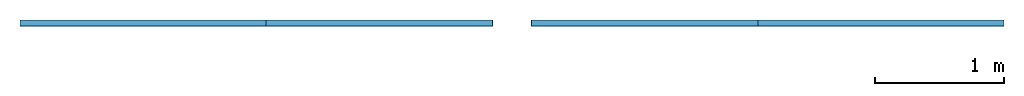
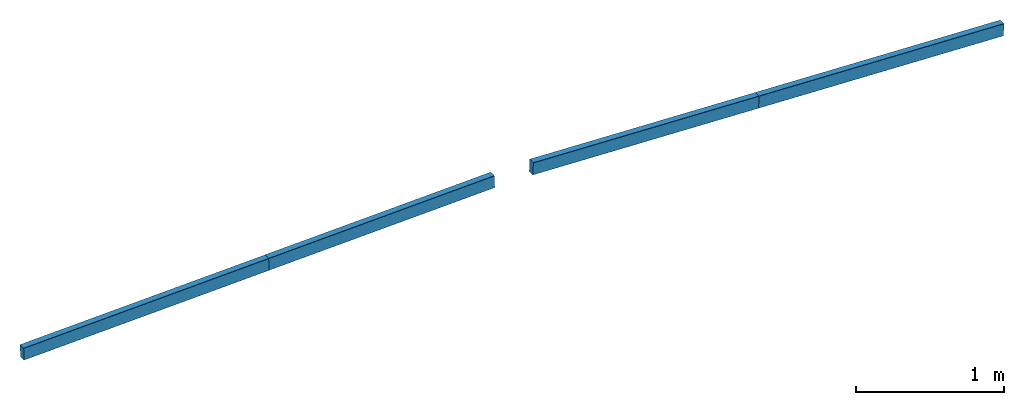
# One storey: 4 members.
"""IFC4 building model written with IfcOpenShell, lengths in metres."""

from ifc_helpers import new_model, entity, si_unit, derived_unit, frame, origin_with_axes, place, context, project, spatial, mirrored_profile, composite_profile, extrude, material, material_profile, profile_set, profile_usage, element, save


model = new_model("IFC4")

# Units and contexts
model_context = context("Model", 3, world=origin_with_axes())
ifc_project = project(units=[si_unit("LENGTHUNIT", "METRE"), si_unit("AREAUNIT", "SQUARE_METRE"), si_unit("VOLUMEUNIT", "CUBIC_METRE"), derived_unit("SECTIONMODULUSUNIT", [(si_unit("LENGTHUNIT", "METRE"), 3)]), derived_unit("MOMENTOFINERTIAUNIT", [(si_unit("LENGTHUNIT", "METRE"), 4)]), si_unit("PLANEANGLEUNIT", "RADIAN"), si_unit("TIMEUNIT", "SECOND"), si_unit("THERMODYNAMICTEMPERATUREUNIT", "DEGREE_CELSIUS"), derived_unit("THERMALEXPANSIONCOEFFICIENTUNIT", [(si_unit("THERMODYNAMICTEMPERATUREUNIT", "DEGREE_CELSIUS"), -1)])], contexts=[model_context])

# Site, building, storey
site = spatial("IfcSite", under=ifc_project, CompositionType="ELEMENT")
building = spatial("IfcBuilding", under=site, Name="Building", CompositionType="ELEMENT")
storey = spatial("IfcBuildingStorey", under=building, Name="LEVEL 7", CompositionType="ELEMENT", Elevation=6.956695)

# Members
ifc_material = material(Name="SAE 1020")
cartesian_point_1 = entity("IfcCartesianPoint", [0.0044999998, 0.050000001])
ifc_direction_1 = entity("IfcDirection", [1.0, 0.0])
cartesian_point_2 = entity("IfcCartesianPoint", [0.0015, 0.046999998])
cartesian_point_3 = entity("IfcCartesianPoint", [0.0015, -0.046999998])
cartesian_point_4 = entity("IfcCartesianPoint", [0.0044999998, -0.050000001])
cartesian_point_5 = entity("IfcCartesianPoint", [0.0044999998, 0.050000001])
ifc_direction_2 = entity("IfcDirection", [1.0, 0.0])
cartesian_point_6 = entity("IfcCartesianPoint", [0.0015, 0.046999998])
cartesian_point_7 = entity("IfcCartesianPoint", [0.0015, -0.046999998])
cartesian_point_8 = entity("IfcCartesianPoint", [0.0044999998, -0.050000001])
ifc_material_profile_1 = material_profile(ifc_material, composite_profile([entity("IfcCenterLineProfileDef", "AREA", None, entity("IfcCompositeCurve", [entity("IfcCompositeCurveSegment", "CONTSAMEGRADIENT", True, entity("IfcPolyline", [entity("IfcCartesianPoint", [0.0515, 0.050000001]), cartesian_point_1])), entity("IfcCompositeCurveSegment", "CONTSAMEGRADIENT", True, entity("IfcTrimmedCurve", entity("IfcCircle", entity("IfcAxis2Placement2D", entity("IfcCartesianPoint", [0.0044999998, 0.047000002]), ifc_direction_1), 0.003), [cartesian_point_1], [cartesian_point_2], True, "CARTESIAN")), entity("IfcCompositeCurveSegment", "CONTSAMEGRADIENT", True, entity("IfcPolyline", [cartesian_point_2, cartesian_point_3])), entity("IfcCompositeCurveSegment", "CONTSAMEGRADIENT", True, entity("IfcTrimmedCurve", entity("IfcCircle", entity("IfcAxis2Placement2D", entity("IfcCartesianPoint", [0.0044999998, -0.047000002]), ifc_direction_1), 0.003), [cartesian_point_3], [cartesian_point_4], True, "CARTESIAN")), entity("IfcCompositeCurveSegment", "CONTSAMEGRADIENT", True, entity("IfcPolyline", [cartesian_point_4, entity("IfcCartesianPoint", [0.0515, -0.050000001])]))], "UNKNOWN"), 0.003), mirrored_profile(entity("IfcCenterLineProfileDef", "AREA", None, entity("IfcCompositeCurve", [entity("IfcCompositeCurveSegment", "CONTSAMEGRADIENT", True, entity("IfcPolyline", [entity("IfcCartesianPoint", [0.0515, 0.050000001]), cartesian_point_5])), entity("IfcCompositeCurveSegment", "CONTSAMEGRADIENT", True, entity("IfcTrimmedCurve", entity("IfcCircle", entity("IfcAxis2Placement2D", entity("IfcCartesianPoint", [0.0044999998, 0.047000002]), ifc_direction_2), 0.003), [cartesian_point_5], [cartesian_point_6], True, "CARTESIAN")), entity("IfcCompositeCurveSegment", "CONTSAMEGRADIENT", True, entity("IfcPolyline", [cartesian_point_6, cartesian_point_7])), entity("IfcCompositeCurveSegment", "CONTSAMEGRADIENT", True, entity("IfcTrimmedCurve", entity("IfcCircle", entity("IfcAxis2Placement2D", entity("IfcCartesianPoint", [0.0044999998, -0.047000002]), ifc_direction_2), 0.003), [cartesian_point_7], [cartesian_point_8], True, "CARTESIAN")), entity("IfcCompositeCurveSegment", "CONTSAMEGRADIENT", True, entity("IfcPolyline", [cartesian_point_8, entity("IfcCartesianPoint", [0.0515, -0.050000001])]))], "UNKNOWN"), 0.003))]))
ifc_profile_set_1 = profile_set([ifc_material_profile_1])
ifc_profile_usage_1 = profile_usage(ifc_profile_set_1, cardinal=10)
member_1_placement = place(None, frame((11.43947, 3.166, 6.956695), z_axis=(0.99930329, 0.0, 0.037321907), x_axis=(0.0, 1.0, 0.0)))
cartesian_point_9 = entity("IfcCartesianPoint", [0.0044999998, 0.050000001])
ifc_direction_3 = entity("IfcDirection", [1.0, 0.0])
cartesian_point_10 = entity("IfcCartesianPoint", [0.0015, 0.046999998])
cartesian_point_11 = entity("IfcCartesianPoint", [0.0015, -0.046999998])
cartesian_point_12 = entity("IfcCartesianPoint", [0.0044999998, -0.050000001])
cartesian_point_13 = entity("IfcCartesianPoint", [0.0044999998, 0.050000001])
ifc_direction_4 = entity("IfcDirection", [1.0, 0.0])
cartesian_point_14 = entity("IfcCartesianPoint", [0.0015, 0.046999998])
cartesian_point_15 = entity("IfcCartesianPoint", [0.0015, -0.046999998])
cartesian_point_16 = entity("IfcCartesianPoint", [0.0044999998, -0.050000001])
element("IfcMember", 1, at=member_1_placement, inside=storey, material=ifc_profile_usage_1, Name="808", context=model_context, shape_type="SweptSolid", body=[
    extrude(composite_profile([entity("IfcCenterLineProfileDef", "AREA", None, entity("IfcCompositeCurve", [entity("IfcCompositeCurveSegment", "CONTSAMEGRADIENT", True, entity("IfcPolyline", [entity("IfcCartesianPoint", [0.0515, 0.050000001]), cartesian_point_9])), entity("IfcCompositeCurveSegment", "CONTSAMEGRADIENT", True, entity("IfcTrimmedCurve", entity("IfcCircle", entity("IfcAxis2Placement2D", entity("IfcCartesianPoint", [0.0044999998, 0.047000002]), ifc_direction_3), 0.003), [cartesian_point_9], [cartesian_point_10], True, "CARTESIAN")), entity("IfcCompositeCurveSegment", "CONTSAMEGRADIENT", True, entity("IfcPolyline", [cartesian_point_10, cartesian_point_11])), entity("IfcCompositeCurveSegment", "CONTSAMEGRADIENT", True, entity("IfcTrimmedCurve", entity("IfcCircle", entity("IfcAxis2Placement2D", entity("IfcCartesianPoint", [0.0044999998, -0.047000002]), ifc_direction_3), 0.003), [cartesian_point_11], [cartesian_point_12], True, "CARTESIAN")), entity("IfcCompositeCurveSegment", "CONTSAMEGRADIENT", True, entity("IfcPolyline", [cartesian_point_12, entity("IfcCartesianPoint", [0.0515, -0.050000001])]))], "UNKNOWN"), 0.003), mirrored_profile(entity("IfcCenterLineProfileDef", "AREA", None, entity("IfcCompositeCurve", [entity("IfcCompositeCurveSegment", "CONTSAMEGRADIENT", True, entity("IfcPolyline", [entity("IfcCartesianPoint", [0.0515, 0.050000001]), cartesian_point_13])), entity("IfcCompositeCurveSegment", "CONTSAMEGRADIENT", True, entity("IfcTrimmedCurve", entity("IfcCircle", entity("IfcAxis2Placement2D", entity("IfcCartesianPoint", [0.0044999998, 0.047000002]), ifc_direction_4), 0.003), [cartesian_point_13], [cartesian_point_14], True, "CARTESIAN")), entity("IfcCompositeCurveSegment", "CONTSAMEGRADIENT", True, entity("IfcPolyline", [cartesian_point_14, cartesian_point_15])), entity("IfcCompositeCurveSegment", "CONTSAMEGRADIENT", True, entity("IfcTrimmedCurve", entity("IfcCircle", entity("IfcAxis2Placement2D", entity("IfcCartesianPoint", [0.0044999998, -0.047000002]), ifc_direction_4), 0.003), [cartesian_point_15], [cartesian_point_16], True, "CARTESIAN")), entity("IfcCompositeCurveSegment", "CONTSAMEGRADIENT", True, entity("IfcPolyline", [cartesian_point_16, entity("IfcCartesianPoint", [0.0515, -0.050000001])]))], "UNKNOWN"), 0.003))]), origin_with_axes(), (0.0, 0.0, 1.0), 1.9065156),
])
cartesian_point_17 = entity("IfcCartesianPoint", [0.0044999998, 0.050000001])
ifc_direction_5 = entity("IfcDirection", [1.0, 0.0])
cartesian_point_18 = entity("IfcCartesianPoint", [0.0015, 0.046999998])
cartesian_point_19 = entity("IfcCartesianPoint", [0.0015, -0.046999998])
cartesian_point_20 = entity("IfcCartesianPoint", [0.0044999998, -0.050000001])
cartesian_point_21 = entity("IfcCartesianPoint", [0.0044999998, 0.050000001])
ifc_direction_6 = entity("IfcDirection", [1.0, 0.0])
cartesian_point_22 = entity("IfcCartesianPoint", [0.0015, 0.046999998])
cartesian_point_23 = entity("IfcCartesianPoint", [0.0015, -0.046999998])
cartesian_point_24 = entity("IfcCartesianPoint", [0.0044999998, -0.050000001])
ifc_material_profile_2 = material_profile(ifc_material, composite_profile([entity("IfcCenterLineProfileDef", "AREA", None, entity("IfcCompositeCurve", [entity("IfcCompositeCurveSegment", "CONTSAMEGRADIENT", True, entity("IfcPolyline", [entity("IfcCartesianPoint", [0.0515, 0.050000001]), cartesian_point_17])), entity("IfcCompositeCurveSegment", "CONTSAMEGRADIENT", True, entity("IfcTrimmedCurve", entity("IfcCircle", entity("IfcAxis2Placement2D", entity("IfcCartesianPoint", [0.0044999998, 0.047000002]), ifc_direction_5), 0.003), [cartesian_point_17], [cartesian_point_18], True, "CARTESIAN")), entity("IfcCompositeCurveSegment", "CONTSAMEGRADIENT", True, entity("IfcPolyline", [cartesian_point_18, cartesian_point_19])), entity("IfcCompositeCurveSegment", "CONTSAMEGRADIENT", True, entity("IfcTrimmedCurve", entity("IfcCircle", entity("IfcAxis2Placement2D", entity("IfcCartesianPoint", [0.0044999998, -0.047000002]), ifc_direction_5), 0.003), [cartesian_point_19], [cartesian_point_20], True, "CARTESIAN")), entity("IfcCompositeCurveSegment", "CONTSAMEGRADIENT", True, entity("IfcPolyline", [cartesian_point_20, entity("IfcCartesianPoint", [0.0515, -0.050000001])]))], "UNKNOWN"), 0.003), mirrored_profile(entity("IfcCenterLineProfileDef", "AREA", None, entity("IfcCompositeCurve", [entity("IfcCompositeCurveSegment", "CONTSAMEGRADIENT", True, entity("IfcPolyline", [entity("IfcCartesianPoint", [0.0515, 0.050000001]), cartesian_point_21])), entity("IfcCompositeCurveSegment", "CONTSAMEGRADIENT", True, entity("IfcTrimmedCurve", entity("IfcCircle", entity("IfcAxis2Placement2D", entity("IfcCartesianPoint", [0.0044999998, 0.047000002]), ifc_direction_6), 0.003), [cartesian_point_21], [cartesian_point_22], True, "CARTESIAN")), entity("IfcCompositeCurveSegment", "CONTSAMEGRADIENT", True, entity("IfcPolyline", [cartesian_point_22, cartesian_point_23])), entity("IfcCompositeCurveSegment", "CONTSAMEGRADIENT", True, entity("IfcTrimmedCurve", entity("IfcCircle", entity("IfcAxis2Placement2D", entity("IfcCartesianPoint", [0.0044999998, -0.047000002]), ifc_direction_6), 0.003), [cartesian_point_23], [cartesian_point_24], True, "CARTESIAN")), entity("IfcCompositeCurveSegment", "CONTSAMEGRADIENT", True, entity("IfcPolyline", [cartesian_point_24, entity("IfcCartesianPoint", [0.0515, -0.050000001])]))], "UNKNOWN"), 0.003))]))
ifc_profile_set_2 = profile_set([ifc_material_profile_2])
ifc_profile_usage_2 = profile_usage(ifc_profile_set_2, cardinal=10)
member_2_placement = place(None, frame((17.154994, 3.166, 7.028178), z_axis=(0.99929685, 0.0, -0.037494075), x_axis=(0.0, 1.0, 0.0)))
cartesian_point_25 = entity("IfcCartesianPoint", [0.0044999998, 0.050000001])
ifc_direction_7 = entity("IfcDirection", [1.0, 0.0])
cartesian_point_26 = entity("IfcCartesianPoint", [0.0015, 0.046999998])
cartesian_point_27 = entity("IfcCartesianPoint", [0.0015, -0.046999998])
cartesian_point_28 = entity("IfcCartesianPoint", [0.0044999998, -0.050000001])
cartesian_point_29 = entity("IfcCartesianPoint", [0.0044999998, 0.050000001])
ifc_direction_8 = entity("IfcDirection", [1.0, 0.0])
cartesian_point_30 = entity("IfcCartesianPoint", [0.0015, 0.046999998])
cartesian_point_31 = entity("IfcCartesianPoint", [0.0015, -0.046999998])
cartesian_point_32 = entity("IfcCartesianPoint", [0.0044999998, -0.050000001])
element("IfcMember", 2, at=member_2_placement, inside=storey, material=ifc_profile_usage_2, Name="811", context=model_context, shape_type="SweptSolid", body=[
    extrude(composite_profile([entity("IfcCenterLineProfileDef", "AREA", None, entity("IfcCompositeCurve", [entity("IfcCompositeCurveSegment", "CONTSAMEGRADIENT", True, entity("IfcPolyline", [entity("IfcCartesianPoint", [0.0515, 0.050000001]), cartesian_point_25])), entity("IfcCompositeCurveSegment", "CONTSAMEGRADIENT", True, entity("IfcTrimmedCurve", entity("IfcCircle", entity("IfcAxis2Placement2D", entity("IfcCartesianPoint", [0.0044999998, 0.047000002]), ifc_direction_7), 0.003), [cartesian_point_25], [cartesian_point_26], True, "CARTESIAN")), entity("IfcCompositeCurveSegment", "CONTSAMEGRADIENT", True, entity("IfcPolyline", [cartesian_point_26, cartesian_point_27])), entity("IfcCompositeCurveSegment", "CONTSAMEGRADIENT", True, entity("IfcTrimmedCurve", entity("IfcCircle", entity("IfcAxis2Placement2D", entity("IfcCartesianPoint", [0.0044999998, -0.047000002]), ifc_direction_7), 0.003), [cartesian_point_27], [cartesian_point_28], True, "CARTESIAN")), entity("IfcCompositeCurveSegment", "CONTSAMEGRADIENT", True, entity("IfcPolyline", [cartesian_point_28, entity("IfcCartesianPoint", [0.0515, -0.050000001])]))], "UNKNOWN"), 0.003), mirrored_profile(entity("IfcCenterLineProfileDef", "AREA", None, entity("IfcCompositeCurve", [entity("IfcCompositeCurveSegment", "CONTSAMEGRADIENT", True, entity("IfcPolyline", [entity("IfcCartesianPoint", [0.0515, 0.050000001]), cartesian_point_29])), entity("IfcCompositeCurveSegment", "CONTSAMEGRADIENT", True, entity("IfcTrimmedCurve", entity("IfcCircle", entity("IfcAxis2Placement2D", entity("IfcCartesianPoint", [0.0044999998, 0.047000002]), ifc_direction_8), 0.003), [cartesian_point_29], [cartesian_point_30], True, "CARTESIAN")), entity("IfcCompositeCurveSegment", "CONTSAMEGRADIENT", True, entity("IfcPolyline", [cartesian_point_30, cartesian_point_31])), entity("IfcCompositeCurveSegment", "CONTSAMEGRADIENT", True, entity("IfcTrimmedCurve", entity("IfcCircle", entity("IfcAxis2Placement2D", entity("IfcCartesianPoint", [0.0044999998, -0.047000002]), ifc_direction_8), 0.003), [cartesian_point_31], [cartesian_point_32], True, "CARTESIAN")), entity("IfcCompositeCurveSegment", "CONTSAMEGRADIENT", True, entity("IfcPolyline", [cartesian_point_32, entity("IfcCartesianPoint", [0.0515, -0.050000001])]))], "UNKNOWN"), 0.003))]), origin_with_axes(), (0.0, 0.0, 1.0), 1.9065146),
])
cartesian_point_33 = entity("IfcCartesianPoint", [0.0044999998, 0.050000001])
ifc_direction_9 = entity("IfcDirection", [1.0, 0.0])
cartesian_point_34 = entity("IfcCartesianPoint", [0.0015, 0.046999998])
cartesian_point_35 = entity("IfcCartesianPoint", [0.0015, -0.046999998])
cartesian_point_36 = entity("IfcCartesianPoint", [0.0044999998, -0.050000001])
cartesian_point_37 = entity("IfcCartesianPoint", [0.0044999998, 0.050000001])
ifc_direction_10 = entity("IfcDirection", [1.0, 0.0])
cartesian_point_38 = entity("IfcCartesianPoint", [0.0015, 0.046999998])
cartesian_point_39 = entity("IfcCartesianPoint", [0.0015, -0.046999998])
cartesian_point_40 = entity("IfcCartesianPoint", [0.0044999998, -0.050000001])
ifc_material_profile_3 = material_profile(ifc_material, composite_profile([entity("IfcCenterLineProfileDef", "AREA", None, entity("IfcCompositeCurve", [entity("IfcCompositeCurveSegment", "CONTSAMEGRADIENT", True, entity("IfcPolyline", [entity("IfcCartesianPoint", [0.0515, 0.050000001]), cartesian_point_33])), entity("IfcCompositeCurveSegment", "CONTSAMEGRADIENT", True, entity("IfcTrimmedCurve", entity("IfcCircle", entity("IfcAxis2Placement2D", entity("IfcCartesianPoint", [0.0044999998, 0.047000002]), ifc_direction_9), 0.003), [cartesian_point_33], [cartesian_point_34], True, "CARTESIAN")), entity("IfcCompositeCurveSegment", "CONTSAMEGRADIENT", True, entity("IfcPolyline", [cartesian_point_34, cartesian_point_35])), entity("IfcCompositeCurveSegment", "CONTSAMEGRADIENT", True, entity("IfcTrimmedCurve", entity("IfcCircle", entity("IfcAxis2Placement2D", entity("IfcCartesianPoint", [0.0044999998, -0.047000002]), ifc_direction_9), 0.003), [cartesian_point_35], [cartesian_point_36], True, "CARTESIAN")), entity("IfcCompositeCurveSegment", "CONTSAMEGRADIENT", True, entity("IfcPolyline", [cartesian_point_36, entity("IfcCartesianPoint", [0.0515, -0.050000001])]))], "UNKNOWN"), 0.003), mirrored_profile(entity("IfcCenterLineProfileDef", "AREA", None, entity("IfcCompositeCurve", [entity("IfcCompositeCurveSegment", "CONTSAMEGRADIENT", True, entity("IfcPolyline", [entity("IfcCartesianPoint", [0.0515, 0.050000001]), cartesian_point_37])), entity("IfcCompositeCurveSegment", "CONTSAMEGRADIENT", True, entity("IfcTrimmedCurve", entity("IfcCircle", entity("IfcAxis2Placement2D", entity("IfcCartesianPoint", [0.0044999998, 0.047000002]), ifc_direction_10), 0.003), [cartesian_point_37], [cartesian_point_38], True, "CARTESIAN")), entity("IfcCompositeCurveSegment", "CONTSAMEGRADIENT", True, entity("IfcPolyline", [cartesian_point_38, cartesian_point_39])), entity("IfcCompositeCurveSegment", "CONTSAMEGRADIENT", True, entity("IfcTrimmedCurve", entity("IfcCircle", entity("IfcAxis2Placement2D", entity("IfcCartesianPoint", [0.0044999998, -0.047000002]), ifc_direction_10), 0.003), [cartesian_point_39], [cartesian_point_40], True, "CARTESIAN")), entity("IfcCompositeCurveSegment", "CONTSAMEGRADIENT", True, entity("IfcPolyline", [cartesian_point_40, entity("IfcCartesianPoint", [0.0515, -0.050000001])]))], "UNKNOWN"), 0.003))]))
ifc_profile_set_3 = profile_set([ifc_material_profile_3])
ifc_profile_usage_3 = profile_usage(ifc_profile_set_3, cardinal=10)
member_3_placement = place(None, frame((13.344645, 3.166, 7.028178), z_axis=(0.99930329, 0.0, 0.037321907), x_axis=(0.0, 1.0, 0.0)))
cartesian_point_41 = entity("IfcCartesianPoint", [0.0044999998, 0.050000001])
ifc_direction_11 = entity("IfcDirection", [1.0, 0.0])
cartesian_point_42 = entity("IfcCartesianPoint", [0.0015, 0.046999998])
cartesian_point_43 = entity("IfcCartesianPoint", [0.0015, -0.046999998])
cartesian_point_44 = entity("IfcCartesianPoint", [0.0044999998, -0.050000001])
cartesian_point_45 = entity("IfcCartesianPoint", [0.0044999998, 0.050000001])
ifc_direction_12 = entity("IfcDirection", [1.0, 0.0])
cartesian_point_46 = entity("IfcCartesianPoint", [0.0015, 0.046999998])
cartesian_point_47 = entity("IfcCartesianPoint", [0.0015, -0.046999998])
cartesian_point_48 = entity("IfcCartesianPoint", [0.0044999998, -0.050000001])
element("IfcMember", 3, at=member_3_placement, inside=storey, material=ifc_profile_usage_3, Name="241", context=model_context, shape_type="SweptSolid", body=[
    extrude(composite_profile([entity("IfcCenterLineProfileDef", "AREA", None, entity("IfcCompositeCurve", [entity("IfcCompositeCurveSegment", "CONTSAMEGRADIENT", True, entity("IfcPolyline", [entity("IfcCartesianPoint", [0.0515, 0.050000001]), cartesian_point_41])), entity("IfcCompositeCurveSegment", "CONTSAMEGRADIENT", True, entity("IfcTrimmedCurve", entity("IfcCircle", entity("IfcAxis2Placement2D", entity("IfcCartesianPoint", [0.0044999998, 0.047000002]), ifc_direction_11), 0.003), [cartesian_point_41], [cartesian_point_42], True, "CARTESIAN")), entity("IfcCompositeCurveSegment", "CONTSAMEGRADIENT", True, entity("IfcPolyline", [cartesian_point_42, cartesian_point_43])), entity("IfcCompositeCurveSegment", "CONTSAMEGRADIENT", True, entity("IfcTrimmedCurve", entity("IfcCircle", entity("IfcAxis2Placement2D", entity("IfcCartesianPoint", [0.0044999998, -0.047000002]), ifc_direction_11), 0.003), [cartesian_point_43], [cartesian_point_44], True, "CARTESIAN")), entity("IfcCompositeCurveSegment", "CONTSAMEGRADIENT", True, entity("IfcPolyline", [cartesian_point_44, entity("IfcCartesianPoint", [0.0515, -0.050000001])]))], "UNKNOWN"), 0.003), mirrored_profile(entity("IfcCenterLineProfileDef", "AREA", None, entity("IfcCompositeCurve", [entity("IfcCompositeCurveSegment", "CONTSAMEGRADIENT", True, entity("IfcPolyline", [entity("IfcCartesianPoint", [0.0515, 0.050000001]), cartesian_point_45])), entity("IfcCompositeCurveSegment", "CONTSAMEGRADIENT", True, entity("IfcTrimmedCurve", entity("IfcCircle", entity("IfcAxis2Placement2D", entity("IfcCartesianPoint", [0.0044999998, 0.047000002]), ifc_direction_12), 0.003), [cartesian_point_45], [cartesian_point_46], True, "CARTESIAN")), entity("IfcCompositeCurveSegment", "CONTSAMEGRADIENT", True, entity("IfcPolyline", [cartesian_point_46, cartesian_point_47])), entity("IfcCompositeCurveSegment", "CONTSAMEGRADIENT", True, entity("IfcTrimmedCurve", entity("IfcCircle", entity("IfcAxis2Placement2D", entity("IfcCartesianPoint", [0.0044999998, -0.047000002]), ifc_direction_12), 0.003), [cartesian_point_47], [cartesian_point_48], True, "CARTESIAN")), entity("IfcCompositeCurveSegment", "CONTSAMEGRADIENT", True, entity("IfcPolyline", [cartesian_point_48, entity("IfcCartesianPoint", [0.0515, -0.050000001])]))], "UNKNOWN"), 0.003))]), origin_with_axes(), (0.0, 0.0, 1.0), 1.7564367),
])
cartesian_point_49 = entity("IfcCartesianPoint", [0.0044999998, 0.050000001])
ifc_direction_13 = entity("IfcDirection", [1.0, 0.0])
cartesian_point_50 = entity("IfcCartesianPoint", [0.0015, 0.046999998])
cartesian_point_51 = entity("IfcCartesianPoint", [0.0015, -0.046999998])
cartesian_point_52 = entity("IfcCartesianPoint", [0.0044999998, -0.050000001])
cartesian_point_53 = entity("IfcCartesianPoint", [0.0044999998, 0.050000001])
ifc_direction_14 = entity("IfcDirection", [1.0, 0.0])
cartesian_point_54 = entity("IfcCartesianPoint", [0.0015, 0.046999998])
cartesian_point_55 = entity("IfcCartesianPoint", [0.0015, -0.046999998])
cartesian_point_56 = entity("IfcCartesianPoint", [0.0044999998, -0.050000001])
ifc_material_profile_4 = material_profile(ifc_material, composite_profile([entity("IfcCenterLineProfileDef", "AREA", None, entity("IfcCompositeCurve", [entity("IfcCompositeCurveSegment", "CONTSAMEGRADIENT", True, entity("IfcPolyline", [entity("IfcCartesianPoint", [0.0515, 0.050000001]), cartesian_point_49])), entity("IfcCompositeCurveSegment", "CONTSAMEGRADIENT", True, entity("IfcTrimmedCurve", entity("IfcCircle", entity("IfcAxis2Placement2D", entity("IfcCartesianPoint", [0.0044999998, 0.047000002]), ifc_direction_13), 0.003), [cartesian_point_49], [cartesian_point_50], True, "CARTESIAN")), entity("IfcCompositeCurveSegment", "CONTSAMEGRADIENT", True, entity("IfcPolyline", [cartesian_point_50, cartesian_point_51])), entity("IfcCompositeCurveSegment", "CONTSAMEGRADIENT", True, entity("IfcTrimmedCurve", entity("IfcCircle", entity("IfcAxis2Placement2D", entity("IfcCartesianPoint", [0.0044999998, -0.047000002]), ifc_direction_13), 0.003), [cartesian_point_51], [cartesian_point_52], True, "CARTESIAN")), entity("IfcCompositeCurveSegment", "CONTSAMEGRADIENT", True, entity("IfcPolyline", [cartesian_point_52, entity("IfcCartesianPoint", [0.0515, -0.050000001])]))], "UNKNOWN"), 0.003), mirrored_profile(entity("IfcCenterLineProfileDef", "AREA", None, entity("IfcCompositeCurve", [entity("IfcCompositeCurveSegment", "CONTSAMEGRADIENT", True, entity("IfcPolyline", [entity("IfcCartesianPoint", [0.0515, 0.050000001]), cartesian_point_53])), entity("IfcCompositeCurveSegment", "CONTSAMEGRADIENT", True, entity("IfcTrimmedCurve", entity("IfcCircle", entity("IfcAxis2Placement2D", entity("IfcCartesianPoint", [0.0044999998, 0.047000002]), ifc_direction_14), 0.003), [cartesian_point_53], [cartesian_point_54], True, "CARTESIAN")), entity("IfcCompositeCurveSegment", "CONTSAMEGRADIENT", True, entity("IfcPolyline", [cartesian_point_54, cartesian_point_55])), entity("IfcCompositeCurveSegment", "CONTSAMEGRADIENT", True, entity("IfcTrimmedCurve", entity("IfcCircle", entity("IfcAxis2Placement2D", entity("IfcCartesianPoint", [0.0044999998, -0.047000002]), ifc_direction_14), 0.003), [cartesian_point_55], [cartesian_point_56], True, "CARTESIAN")), entity("IfcCompositeCurveSegment", "CONTSAMEGRADIENT", True, entity("IfcPolyline", [cartesian_point_56, entity("IfcCartesianPoint", [0.0515, -0.050000001])]))], "UNKNOWN"), 0.003))]))
ifc_profile_set_4 = profile_set([ifc_material_profile_4])
ifc_profile_usage_4 = profile_usage(ifc_profile_set_4, cardinal=10)
member_4_placement = place(None, frame((15.399755, 3.166, 7.094078), z_axis=(0.99929685, 0.0, -0.037494075), x_axis=(0.0, 1.0, 0.0)))
cartesian_point_57 = entity("IfcCartesianPoint", [0.0044999998, 0.050000001])
ifc_direction_15 = entity("IfcDirection", [1.0, 0.0])
cartesian_point_58 = entity("IfcCartesianPoint", [0.0015, 0.046999998])
cartesian_point_59 = entity("IfcCartesianPoint", [0.0015, -0.046999998])
cartesian_point_60 = entity("IfcCartesianPoint", [0.0044999998, -0.050000001])
cartesian_point_61 = entity("IfcCartesianPoint", [0.0044999998, 0.050000001])
ifc_direction_16 = entity("IfcDirection", [1.0, 0.0])
cartesian_point_62 = entity("IfcCartesianPoint", [0.0015, 0.046999998])
cartesian_point_63 = entity("IfcCartesianPoint", [0.0015, -0.046999998])
cartesian_point_64 = entity("IfcCartesianPoint", [0.0044999998, -0.050000001])
element("IfcMember", 4, at=member_4_placement, inside=storey, material=ifc_profile_usage_4, Name="244", context=model_context, shape_type="SweptSolid", body=[
    extrude(composite_profile([entity("IfcCenterLineProfileDef", "AREA", None, entity("IfcCompositeCurve", [entity("IfcCompositeCurveSegment", "CONTSAMEGRADIENT", True, entity("IfcPolyline", [entity("IfcCartesianPoint", [0.0515, 0.050000001]), cartesian_point_57])), entity("IfcCompositeCurveSegment", "CONTSAMEGRADIENT", True, entity("IfcTrimmedCurve", entity("IfcCircle", entity("IfcAxis2Placement2D", entity("IfcCartesianPoint", [0.0044999998, 0.047000002]), ifc_direction_15), 0.003), [cartesian_point_57], [cartesian_point_58], True, "CARTESIAN")), entity("IfcCompositeCurveSegment", "CONTSAMEGRADIENT", True, entity("IfcPolyline", [cartesian_point_58, cartesian_point_59])), entity("IfcCompositeCurveSegment", "CONTSAMEGRADIENT", True, entity("IfcTrimmedCurve", entity("IfcCircle", entity("IfcAxis2Placement2D", entity("IfcCartesianPoint", [0.0044999998, -0.047000002]), ifc_direction_15), 0.003), [cartesian_point_59], [cartesian_point_60], True, "CARTESIAN")), entity("IfcCompositeCurveSegment", "CONTSAMEGRADIENT", True, entity("IfcPolyline", [cartesian_point_60, entity("IfcCartesianPoint", [0.0515, -0.050000001])]))], "UNKNOWN"), 0.003), mirrored_profile(entity("IfcCenterLineProfileDef", "AREA", None, entity("IfcCompositeCurve", [entity("IfcCompositeCurveSegment", "CONTSAMEGRADIENT", True, entity("IfcPolyline", [entity("IfcCartesianPoint", [0.0515, 0.050000001]), cartesian_point_61])), entity("IfcCompositeCurveSegment", "CONTSAMEGRADIENT", True, entity("IfcTrimmedCurve", entity("IfcCircle", entity("IfcAxis2Placement2D", entity("IfcCartesianPoint", [0.0044999998, 0.047000002]), ifc_direction_16), 0.003), [cartesian_point_61], [cartesian_point_62], True, "CARTESIAN")), entity("IfcCompositeCurveSegment", "CONTSAMEGRADIENT", True, entity("IfcPolyline", [cartesian_point_62, cartesian_point_63])), entity("IfcCompositeCurveSegment", "CONTSAMEGRADIENT", True, entity("IfcTrimmedCurve", entity("IfcCircle", entity("IfcAxis2Placement2D", entity("IfcCartesianPoint", [0.0044999998, -0.047000002]), ifc_direction_16), 0.003), [cartesian_point_63], [cartesian_point_64], True, "CARTESIAN")), entity("IfcCompositeCurveSegment", "CONTSAMEGRADIENT", True, entity("IfcPolyline", [cartesian_point_64, entity("IfcCartesianPoint", [0.0515, -0.050000001])]))], "UNKNOWN"), 0.003))]), origin_with_axes(), (0.0, 0.0, 1.0), 1.7564757),
])

save(model, "model.ifc")
